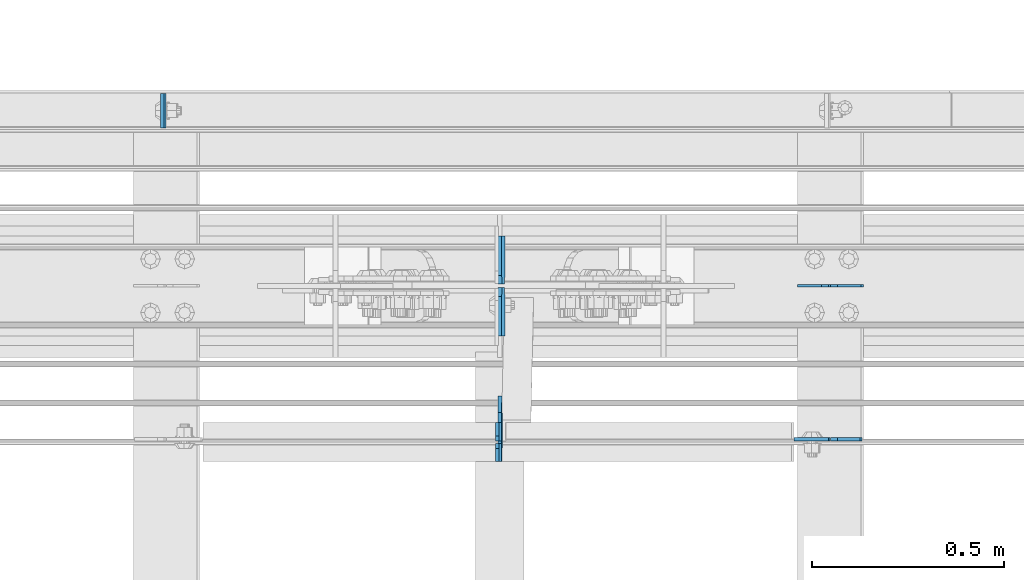
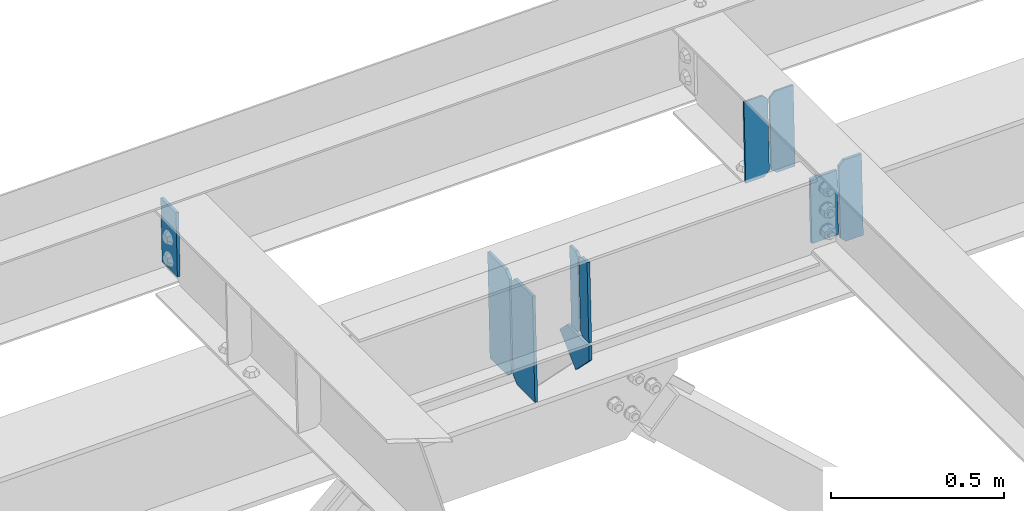
# One storey, part 3648 of 3843: 10 plates, 4 elements without a shape of their own.
"""IFC2X3 building model written with IfcOpenShell, lengths in millimetres."""

from ifc_helpers import new_model, si_unit, frame, origin_with_axes, place, context, subcontext, project, spatial, faceted_brep, material, type_object, element, aggregate, save


model = new_model("IFC2X3")

# Units and contexts
model_context = context("Model", 3, precision=1e-05, world=origin_with_axes())
body_context = subcontext(model_context, "Body", "Model", "MODEL_VIEW")
ifc_project = project(units=[si_unit("LENGTHUNIT", "METRE", prefix="MILLI"), si_unit("AREAUNIT", "SQUARE_METRE"), si_unit("VOLUMEUNIT", "CUBIC_METRE"), si_unit("MASSUNIT", "GRAM", prefix="KILO"), si_unit("TIMEUNIT", "SECOND"), si_unit("PLANEANGLEUNIT", "RADIAN"), si_unit("SOLIDANGLEUNIT", "STERADIAN"), si_unit("THERMODYNAMICTEMPERATUREUNIT", "DEGREE_CELSIUS"), si_unit("LUMINOUSINTENSITYUNIT", "LUMEN")], contexts=[model_context])

# Site, building, storey
site_placement = place(None, origin_with_axes())
site = spatial("IfcSite", under=ifc_project, at=site_placement, CompositionType="ELEMENT")
building_placement = place(site_placement, origin_with_axes())
building = spatial("IfcBuilding", under=site, at=building_placement, Name="Undefined", CompositionType="ELEMENT")
storey_placement = place(building_placement, origin_with_axes())
storey = spatial("IfcBuildingStorey", under=building, at=storey_placement, Name="Undefined", CompositionType="ELEMENT", Elevation=0.0)

# Assembly, plate
assembly_1_placement = place(storey_placement, origin_with_axes())
assembly_1 = element("IfcElementAssembly", 1, at=assembly_1_placement, inside=storey, Name="CHANNEL", AssemblyPlace="NOTDEFINED", PredefinedType="RIGID_FRAME")
ifc_material = material(Name="STEEL/A572-50")
plate_type_1 = type_object("IfcPlateType", PredefinedType="NOTDEFINED")
plate_1_placement = place(assembly_1_placement, frame((80453.4886955898, 105059.162500026, 46619.7947536433), z_axis=(0.0, -1.0, 0.0), x_axis=(0.0211520550054438, 0.0, -0.999776270257025)))
plate_1 = element("IfcPlate", 2, at=plate_1_placement, type_object=plate_type_1, material=ifc_material, Name="PLATE", context=body_context, shape_type="Brep", body=[
    faceted_brep([(0.0, -4.76249999999709, 0.0), (0.0, -4.76249999999709, 88.9000015258789), (0.0, 4.76249999999709, 88.9000015258789), (0.0, 4.76249999999709, 0.0), (228.600006102781, -4.7625000004191, 88.9000015257589), (228.600006102781, 4.76249999954598, 88.9000015257443), (228.600006103079, -4.7625000004482, 7.27595761418343e-12), (228.600006103079, 4.76249999954598, -7.27595761418343e-12)], [[[0, 1, 2, 3]], [[1, 4, 5, 2]], [[4, 6, 7, 5]], [[6, 0, 3, 7]], [[5, 7, 3, 2]], [[6, 4, 1, 0]]]),
])
aggregate(assembly_1, [plate_1])

assembly_2_placement = place(storey_placement, origin_with_axes())
assembly_2 = element("IfcElementAssembly", 3, at=assembly_2_placement, inside=storey, Name="BEAM", AssemblyPlace="NOTDEFINED", PredefinedType="RIGID_FRAME")
plate_2_placement = place(assembly_2_placement, frame((82185.4501303985, 104160.6375, 46656.437554205), z_axis=(-0.999776270257024, 0.0, -0.0211520550054595), x_axis=(0.0211520550054438, 0.0, -0.999776270257025)))
plate_2 = element("IfcPlate", 4, at=plate_2_placement, type_object=plate_type_1, material=ifc_material, Name="PLATE", context=body_context, shape_type="Brep", body=[
    faceted_brep([(0.0, -4.76249999999709, 0.0), (0.0, -4.76249999999709, 88.9000015258789), (0.0, 4.76249999999709, 88.9000015258789), (0.0, 4.76249999999709, 0.0), (228.600006102781, -4.7625000004191, 88.9000015257589), (228.600006102781, 4.76249999954598, 88.9000015257443), (228.600006103079, -4.7625000004482, 7.27595761418343e-12), (228.600006103079, 4.76249999954598, -7.27595761418343e-12)], [[[0, 1, 2, 3]], [[1, 4, 5, 2]], [[4, 6, 7, 5]], [[6, 0, 3, 7]], [[5, 7, 3, 2]], [[6, 4, 1, 0]]]),
])

# Assembly, plates
assembly_3_placement = place(storey_placement, origin_with_axes())
assembly_3 = element("IfcElementAssembly", 5, at=assembly_3_placement, inside=storey, Name="BEAM", AssemblyPlace="NOTDEFINED", PredefinedType="RIGID_FRAME")
plate_type_2 = type_object("IfcPlateType", PredefinedType="NOTDEFINED")
plate_3_placement = place(assembly_3_placement, frame((81330.4977897556, 104101.9, 46379.5290655881), z_axis=(-0.0211520980073474, 0.0, 0.999776269347241), x_axis=(0.0, 1.0, 0.0)))
plate_3 = element("IfcPlate", 6, at=plate_3_placement, type_object=plate_type_2, material=ifc_material, Name="STIFFENER", context=body_context, shape_type="Brep", body=[
    faceted_brep([(0.0, -4.76249999999709, 0.0), (0.0, -4.7624999997206, 285.749999997672), (0.0, 4.7625000002663, 285.749999997664), (0.0, 4.76249999999709, 0.0), (34.9250001907349, -4.7624999997206, 285.749999997672), (34.9250001907349, 4.7625000002663, 285.749999997664), (47.625, -4.76249999972788, 273.050000188428), (47.625, 4.76250000025902, 273.050000188421), (47.625, -4.76249999998981, 12.6999998092579), (47.625, 4.76249999999709, 12.6999998092506), (34.9250001907349, -4.76249999999709, 1.45519152283669e-11), (34.9250001907349, 4.76249999998254, 0.0)], [[[0, 1, 2, 3]], [[1, 4, 5, 2]], [[4, 6, 7, 5]], [[6, 8, 9, 7]], [[8, 10, 11, 9]], [[10, 0, 3, 11]], [[5, 7, 9, 11, 3, 2]], [[10, 8, 6, 4, 1, 0]]]),
])
plate_4_placement = place(assembly_3_placement, frame((81330.4977897556, 104155.875, 46379.5290655881), z_axis=(-0.0211520980073474, 0.0, 0.999776269347241), x_axis=(0.0, 1.0, 0.0)))
plate_4 = element("IfcPlate", 7, at=plate_4_placement, type_object=plate_type_2, material=ifc_material, Name="STIFFENER", context=body_context, shape_type="Brep", body=[
    faceted_brep([(0.0, -4.76250000000073, 12.6999998092651), (0.0, -4.76250000000073, 273.050000188858), (0.0, 4.76250000000073, 273.050000188858), (0.0, 4.76250000000073, 12.6999998092651), (12.6999998092651, -4.76250000000073, 285.749999998123), (12.6999998092651, 4.76250000000073, 285.749999998123), (47.625, -4.76250000000073, 285.749999998123), (47.625, 4.76250000000073, 285.749999998123), (47.625, -4.76250000000073, 0.0), (47.625, 4.76250000000073, 0.0), (12.6999998092651, -4.76250000000073, 0.0), (12.6999998092651, 4.76250000000073, 0.0)], [[[0, 1, 2, 3]], [[1, 4, 5, 2]], [[4, 6, 7, 5]], [[6, 8, 9, 7]], [[8, 10, 11, 9]], [[10, 0, 3, 11]], [[5, 7, 9, 11, 3, 2]], [[10, 8, 6, 4, 1, 0]]]),
])

# Plate
plate_type_3 = type_object("IfcPlateType", PredefinedType="NOTDEFINED")
plate_5_placement = place(assembly_2_placement, frame((82276.6964784351, 104559.100000002, 46396.371936814), z_axis=(-0.0211520980073474, 0.0, 0.999776269347241), x_axis=(-0.999776270257024, 0.0, -0.0211520550054595)))
plate_5 = element("IfcPlate", 8, at=plate_5_placement, type_object=plate_type_3, material=ifc_material, Name="STIFFENER", context=body_context, shape_type="Brep", body=[
    faceted_brep([(0.0, -3.17499999999927, 0.0), (6.83940015733242e-10, -3.17499999996653, 288.924999998613), (6.54836185276508e-10, 3.17500000001746, 288.924999998591), (0.0, 3.17499999999927, 0.0), (61.9125003828667, -3.17499999997744, 288.924999998599), (61.9125003828522, 3.17500000002838, 288.924999998584), (79.3750000013097, -3.17499999997744, 271.462500380039), (79.375000001266, 3.17500000002838, 271.462500380017), (79.375000000713, -3.17499999999927, 17.4624996185448), (79.3750000006694, 3.17500000000291, 17.462499618523), (61.9125003821828, -3.17499999999563, -1.45519152283669e-11), (61.9125003821682, 3.17500000000655, -2.91038304567337e-11)], [[[0, 1, 2, 3]], [[1, 4, 5, 2]], [[4, 6, 7, 5]], [[6, 8, 9, 7]], [[8, 10, 11, 9]], [[10, 0, 3, 11]], [[5, 7, 9, 11, 3, 2]], [[10, 8, 6, 4, 1, 0]]]),
])

plate_6_placement = place(assembly_2_placement, frame((82190.9906577448, 104559.100000002, 46394.5586732123), z_axis=(-0.0211520980073474, 0.0, 0.999776269347241), x_axis=(-0.999776270257024, 0.0, -0.0211520550054595)))
plate_6 = element("IfcPlate", 9, at=plate_6_placement, type_object=plate_type_3, material=ifc_material, Name="STIFFENER", context=body_context, shape_type="Brep", body=[
    faceted_brep([(5.82076609134674e-11, -3.17499999999927, 17.4624996185667), (6.25732354819775e-10, -3.17499999997744, 271.462500380054), (5.82076609134674e-10, 3.17500000002474, 271.462500380039), (0.0, 3.17500000000655, 17.4624996185521), (17.462499619156, -3.17499999997744, 288.924999998606), (17.4624996191269, 3.17500000002474, 288.924999998591), (79.3750000013242, -3.17500000025029, 288.924999998591), (79.3750000013097, 3.1749999997337, 288.92499999857), (79.3750000006548, -3.17500000026484, -2.18278728425503e-11), (79.3750000006403, 3.17499999969732, -2.91038304567337e-11), (17.4624996184866, -3.17500000000291, 7.27595761418343e-12), (17.462499618443, 3.17500000000291, -7.27595761418343e-12)], [[[0, 1, 2, 3]], [[1, 4, 5, 2]], [[4, 6, 7, 5]], [[6, 8, 9, 7]], [[8, 10, 11, 9]], [[10, 0, 3, 11]], [[5, 7, 9, 11, 3, 2]], [[10, 8, 6, 4, 1, 0]]]),
])

plate_type_4 = type_object("IfcPlateType", PredefinedType="NOTDEFINED")
plate_7_placement = place(assembly_2_placement, frame((82197.3392370552, 104160.6375, 46394.6929890346), z_axis=(-0.0211520980073474, 0.0, 0.999776269347241), x_axis=(0.999776270257024, 0.0, 0.0211520550054619)))
plate_7 = element("IfcPlate", 10, at=plate_7_placement, type_object=plate_type_4, material=ifc_material, Name="PLATE", context=body_context, shape_type="Brep", body=[
    faceted_brep([(-1.45519152283669e-11, -4.76250000000073, 17.4624996184939), (-3.34694050252438e-10, -4.76250000000073, 271.462500379137), (-3.34694050252438e-10, 4.76250000000073, 271.462500379137), (-1.45519152283669e-11, 4.76250000000073, 17.4624996184939), (17.4624996182974, -4.76250000000073, 288.924999997646), (17.4624996182974, 4.76250000000073, 288.924999997646), (76.2000000009575, -4.76250000000073, 288.924999997696), (76.2000000009575, 4.76250000000073, 288.924999997696), (76.2000000012922, -4.76250000000073, 7.27595761418343e-11), (76.2000000012922, 4.76250000000073, 7.27595761418343e-11), (17.4624996186321, -4.76250000000073, 7.27595761418343e-12), (17.4624996186321, 4.76250000000073, 7.27595761418343e-12)], [[[0, 1, 2, 3]], [[1, 4, 5, 2]], [[4, 6, 7, 5]], [[6, 8, 9, 7]], [[8, 10, 11, 9]], [[10, 0, 3, 11]], [[5, 7, 9, 11, 3, 2]], [[10, 8, 6, 4, 1, 0]]]),
])

aggregate(assembly_2, [plate_7, plate_5, plate_6, plate_2])

# Assembly, plates
assembly_4_placement = place(storey_placement, origin_with_axes())
assembly_4 = element("IfcElementAssembly", 11, at=assembly_4_placement, inside=storey, Name="BEAM", AssemblyPlace="NOTDEFINED", PredefinedType="RIGID_FRAME")
plate_type_5 = type_object("IfcPlateType", PredefinedType="NOTDEFINED")
plate_8_placement = place(assembly_4_placement, frame((81339.1947389233, 104428.925, 45968.4585708097), z_axis=(-0.0211520980073474, 0.0, 0.999776269347241), x_axis=(0.0, 1.0, 0.0)))
plate_8 = element("IfcPlate", 12, at=plate_8_placement, type_object=plate_type_5, material=ifc_material, Name="STIFFENER", context=body_context, shape_type="Brep", body=[
    faceted_brep([(0.0, -4.76249999999709, 0.0), (0.0, -4.76249999999709, 377.824999997538), (0.0, 4.76249999999709, 377.824999997538), (0.0, 4.76249999999709, 0.0), (103.187499618536, -4.76249999999709, 377.824999997538), (103.187499618536, 4.76249999999709, 377.824999997538), (125.412500000006, -4.76249999999709, 355.599999616068), (125.412500000006, 4.76249999999709, 355.599999616068), (125.412500000006, -4.76249999999709, 22.2250003814697), (125.412500000006, 4.76249999999709, 22.2250003814697), (103.187499618536, -4.76249999999709, 0.0), (103.187499618536, 4.76249999999709, 0.0)], [[[0, 1, 2, 3]], [[1, 4, 5, 2]], [[4, 6, 7, 5]], [[6, 8, 9, 7]], [[8, 10, 11, 9]], [[10, 0, 3, 11]], [[5, 7, 9, 11, 3, 2]], [[10, 8, 6, 4, 1, 0]]]),
])
plate_9_placement = place(assembly_4_placement, frame((81339.1947389233, 104563.8625, 45968.4585708097), z_axis=(-0.0211520980073474, 0.0, 0.999776269347241), x_axis=(0.0, 1.0, 0.0)))
plate_9 = element("IfcPlate", 13, at=plate_9_placement, type_object=plate_type_5, material=ifc_material, Name="STIFFENER", context=body_context, shape_type="Brep", body=[
    faceted_brep([(0.0, -4.76249999999709, 22.2250003814697), (0.0, -4.76249999999709, 355.599999616068), (0.0, 4.76249999999709, 355.599999616068), (0.0, 4.76249999999709, 22.2250003814697), (22.2250003814697, -4.76249999999709, 377.824999997538), (22.2250003814697, 4.76249999999709, 377.824999997538), (125.412500000006, -4.76249999999709, 377.824999997538), (125.412500000006, 4.76249999999709, 377.824999997538), (125.412500000006, -4.76249999999709, 0.0), (125.412500000006, 4.76249999999709, 0.0), (22.2250003814697, -4.76249999999709, 0.0), (22.2250003814697, 4.76249999999709, 0.0)], [[[0, 1, 2, 3]], [[1, 4, 5, 2]], [[4, 6, 7, 5]], [[6, 8, 9, 7]], [[8, 10, 11, 9]], [[10, 0, 3, 11]], [[5, 7, 9, 11, 3, 2]], [[10, 8, 6, 4, 1, 0]]]),
])
aggregate(assembly_4, [plate_8, plate_9])

# Plate
plate_type_6 = type_object("IfcPlateType", PredefinedType="NOTDEFINED")
plate_10_placement = place(assembly_3_placement, frame((81330.7328421347, 104229.802575634, 46368.4190517794), z_axis=(0.0149567919892506, -0.707106781418042, -0.706948579492178), x_axis=(0.0149567919991071, 0.70710678095505, -0.706948579955064)))
plate_10 = element("IfcPlate", 14, at=plate_10_placement, type_object=plate_type_6, material=ifc_material, Name="PLATE", context=body_context, shape_type="Brep", body=[
    faceted_brep([(0.0, -4.76249999999709, 0.0), (-90.4407785346557, -4.7624999996915, 90.4407785903313), (-90.4407785346702, 4.76250000022992, 90.4407785903604), (0.0, 4.76249999999709, 0.0), (-53.8870295345769, -4.76249999940046, 127.000000010928), (-53.8870295345769, 4.76250000053551, 127.000000010928), (61.3210243802823, -4.76249999909487, 127.00000001915), (61.3210243802605, 4.7625000008411, 127.00000001915), (61.3210243731082, -4.76249999982247, 5.82076609134674e-11), (61.321024373101, 4.7625000001135, 4.36557456851006e-11)], [[[0, 1, 2, 3]], [[1, 4, 5, 2]], [[4, 6, 7, 5]], [[6, 8, 9, 7]], [[8, 0, 3, 9]], [[5, 7, 9, 3, 2]], [[8, 6, 4, 1, 0]]]),
])

aggregate(assembly_3, [plate_3, plate_4, plate_10])

save(model, "model.ifc")
